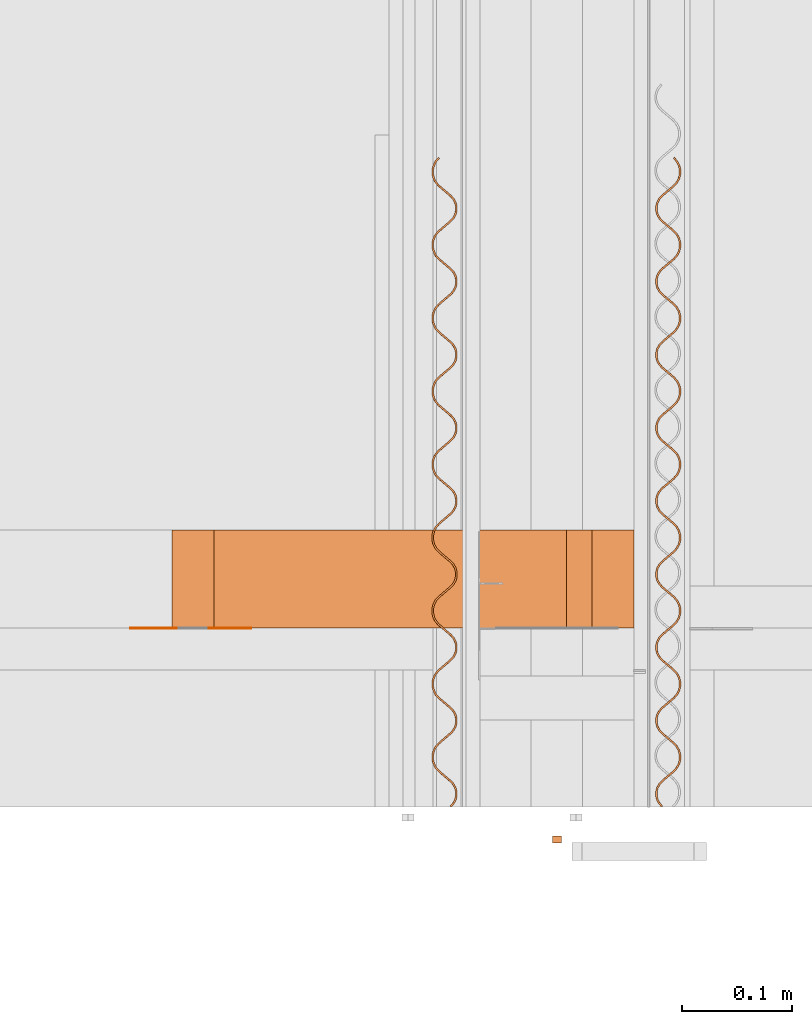
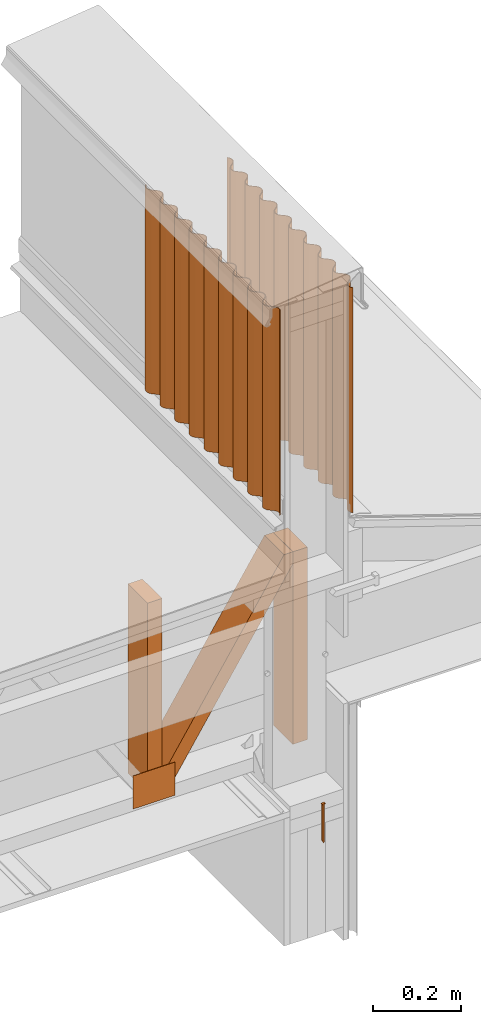
# One storey, part 10 of 22: 7 proxies.
"""IFC2X3 building model written with IfcOpenShell, lengths in feet."""

from ifc_helpers import new_model, entity, si_unit, converted_unit, frame, frame_2d, origin_with_axes, place, context, subcontext, project, spatial, polyline, rectangle, outline, extrude, source, transform, mapped, type_object, type_shapes, element, save


model = new_model("IFC2X3")

# Units and contexts
model_context = context("Model", 3, precision=1e-05)
plan_context = context("Plan", 2, precision=1e-05, world=frame_2d((0.0, 0.0, 0.0), x_axis=(1.0, 0.0, 0.0)))
body_context_1 = subcontext(model_context, "Body", "Model", "MODEL_VIEW")
body_context_2 = subcontext(model_context, "Body", "Model", "MODEL_VIEW")
ifc_project = project(units=[converted_unit("VOLUMEUNIT", "cubic foot", entity("IfcReal", 0.0283168467116885), si_unit("VOLUMEUNIT", "CUBIC_METRE"), dimensions=[3, 0, 0, 0, 0, 0, 0]), converted_unit("AREAUNIT", "square foot", entity("IfcReal", 0.09290304), si_unit("AREAUNIT", "SQUARE_METRE"), dimensions=[2, 0, 0, 0, 0, 0, 0]), converted_unit("LENGTHUNIT", "foot", entity("IfcReal", 0.3048), si_unit("LENGTHUNIT", "METRE"), dimensions=[1, 0, 0, 0, 0, 0, 0])], contexts=[model_context, plan_context])

# Site, building, storey
site_placement = place(None, origin_with_axes())
site = spatial("IfcSite", under=ifc_project, at=site_placement, CompositionType="ELEMENT")
building_placement = place(site_placement, origin_with_axes())
building = spatial("IfcBuilding", under=site, at=building_placement, Name="Building", CompositionType="ELEMENT")
storey_placement = place(building_placement, origin_with_axes())
storey = spatial("IfcBuildingStorey", under=building, at=storey_placement, Name="Storey", CompositionType="ELEMENT")

# Proxies
building_element_proxy_type = type_object("IfcBuildingElementProxyType", PredefinedType="NOTDEFINED")
shared_shape = source(origin_with_axes(), body_context_1, "Body", "SweptSolid", [
    extrude(outline(polyline([(0.111323627313291, -4.3989495809459e-10), (0.11174819796417, -0.00686187809210984), (0.11861007758404, -0.00643729980243003), (0.11691175831428, 0.0210102125660093), (0.110049890916491, 0.0205856327485694), (0.110474473789452, 0.0137237546564596), (-0.222222659531541, -0.00686187580046965), (-0.235521848120402, -0.0145729081802989), (-0.22137349378562, -0.0205856312208093), (0.111323627313291, -4.3989495809459e-10)])), frame((0.111111134212474, 9.54850080601499e-11, -0.0200000086804153), z_axis=(-5.63213937709861e-08, 0.0, -1.0), x_axis=(-0.998091220855713, -0.0617568753659725, 6.86179575382084e-08)), (-2.94874541451051e-10, 4.76513584146687e-09, -0.999999940395355), 0.0199999997321788),
])
type_shapes(building_element_proxy_type, [shared_shape])
proxy_1_placement = place(storey_placement, frame((1615.7385558281, 1.80479852859117, -61.6394691267039), z_axis=(-1.62920684942947e-07, 1.0, -1.23001694617955e-14), x_axis=(7.54979012640433e-08, 0.0, -1.0)))
element("IfcBuildingElementProxy", 1, at=proxy_1_placement, inside=storey, type_object=building_element_proxy_type, context=body_context_1, shape_type="MappedRepresentation", body=[
    mapped(shared_shape, transform((0.0, 0.0, 0.0), x_axis=(1.0, 0.0, 0.0), y_axis=(0.0, 1.0, 0.0), z_axis=(0.0, 0.0, 1.0), scale=1.0)),
])
proxy_2_placement = place(storey_placement, frame((1616.04983912991, 1.89103577237117, -57.2210972703348), z_axis=(-5.64259664770361e-07, -8.02678698619275e-07, 1.0), x_axis=(1.0, 3.25841369885893e-07, 5.64259948987456e-07)))
element("IfcBuildingElementProxy", 2, at=proxy_2_placement, inside=storey, Name="Generic Models 1:Generic Models 1", context=body_context_2, shape_type="SweptSolid", body=[
    extrude(outline(polyline([(-0.165153717685716, 0.164683680893399), (-0.119867326393528, 0.164683680893399), (-0.107156533229695, 0.163006444713419), (-0.0951571629585556, 0.158297594666012), (-0.0846319162137709, 0.150837664177099), (-0.0762915314514962, 0.141000245597575), (-0.0706418561614717, 0.129382020923409), (-0.0679718325613678, 0.116788474182914), (-0.0683844561280384, 0.103960165709961), (-0.0758012976702743, 0.0592933300383917), (-0.0762221772526819, 0.0464747533974607), (-0.0736202917543296, 0.0338066458516312), (-0.0679022644761353, 0.0222627130970163), (-0.0595618491586581, 0.0124253204894152), (-0.0491048902361177, 0.00489097280462035), (-0.0370373879742669, 0.000256724716585833), (-0.0243185419867945, -0.00143010551054911), (0.0209679272211599, -0.00143027385061832), (0.0336706935332751, -0.00309803190224332), (0.0456780601009296, -0.00781619192890608), (0.0561992002264878, -0.0152714321942232), (0.064539639988127, -0.0251088018854224), (0.0701852514362085, -0.0367221866154999), (0.0728635799403735, -0.0493256637968338), (0.072446788644071, -0.0621490009383267), (0.0650217277523414, -0.106806162832759), (0.064601110944676, -0.119625011414993), (0.0672150351928444, -0.132307424906671), (0.0729289069634879, -0.143846377163265), (0.0812652034396575, -0.153678980242862), (0.0917221654177181, -0.161213330983177), (0.103789985453676, -0.165847956332478), (0.116504787460087, -0.167529971346142), (0.161795248705258, -0.167534664625258), (0.174505821871632, -0.169211815250671), (0.186505461028555, -0.173920836407212), (0.197026619487234, -0.181375975840361), (0.205366967583266, -0.191213418864046), (0.211016600096007, -0.202831447984916), (0.213690693649094, -0.215429920224067), (0.213277978416816, -0.228258069809966), (0.205857170809285, -0.272920267201784), (0.205436511224336, -0.285739128006099), (0.208042136679484, -0.298411641612141), (0.213760090625192, -0.309955592699877), (0.222100756495331, -0.319793194610616), (0.232553446856071, -0.32732255874187), (0.24462507407027, -0.331961694039072), (0.257339924965005, -0.33364364794233), (0.302630606207635, -0.333648658995553), (0.3153332594655, -0.335316435284815), (0.327336614135056, -0.34002988083469), (0.337857674817088, -0.347485032489919), (0.346202276197318, -0.35732727879145), (0.351847899867481, -0.368940651299447), (0.354526051151471, -0.381544061259335), (0.354109375964938, -0.394367517566118), (0.346684290629046, -0.439024630572226), (0.346263533267449, -0.451843344711569), (0.348873583115931, -0.464521016035806), (0.354591561505801, -0.476064869346894), (0.362923745251703, -0.485892742481132), (0.373380762229128, -0.493426824335664), (0.385452413887489, -0.498066179630325), (0.398171298068965, -0.499753120142644), (0.443453619408169, -0.499748231310231), (0.456164437016164, -0.501425540822697), (0.468167840574044, -0.506139108593383), (0.478688999032724, -0.513594333581098), (0.48702939601708, -0.523431593273568), (0.492679272971441, -0.535049952390626), (0.495353415412853, -0.547648424629777), (0.494936642449672, -0.560472027601532), (0.487519648131423, -0.60513860049836), (0.487098915213988, -0.617957265749378), (0.489704809554919, -0.630630243794499), (0.49541877910221, -0.642169306049822), (0.503759127198242, -0.652006712407265), (0.514211988668116, -0.659536052094357), (0.526287649169056, -0.664180149556458), (0.539002573396277, -0.665862299013013), (0.58428499251213, -0.665857556845572), (0.596991459059277, -0.667529781972329), (0.608999115901356, -0.672248189687103), (0.619520372136684, -0.679703610228115), (0.627860622456067, -0.689540821032261), (0.633510450522105, -0.70115908237267), (0.636180437455966, -0.713752763556057), (0.63576786888866, -0.726581157583577), (0.640853379029302, -0.727470387311119), (0.641342653377162, -0.713338826115676), (0.638466504380459, -0.699418266927163), (0.632248593988068, -0.686665356472095), (0.623082570985859, -0.675854339139668), (0.611515202390866, -0.6676294163769), (0.598252631156776, -0.66251467101843), (0.584235273086493, -0.660689669878777), (0.539029364197899, -0.660629830570046), (0.52762102932129, -0.659095323852354), (0.516812309740097, -0.654861937201242), (0.507237091464946, -0.648212734013405), (0.499726378229346, -0.639354071904981), (0.494745489102336, -0.628834331207701), (0.492333143636623, -0.617473613558792), (0.492677806321717, -0.605958555470614), (0.50002234814361, -0.561361355105723), (0.500511280273202, -0.547229549468659), (0.497635326829795, -0.533309283610091), (0.491421669721603, -0.52056131087576), (0.482247433480941, -0.509740466990183), (0.470683633733609, -0.501520090841559), (0.45741739587521, -0.496400652203973), (0.443412308774282, -0.494590268673233), (0.398198137758911, -0.494520553923029), (0.386793885057367, -0.492991033814398), (0.375981181077757, -0.488752807219197), (0.366409898312699, -0.482108297310476), (0.358899160632937, -0.473249439648756), (0.353914189330862, -0.462725054560684), (0.351510081547765, -0.451374065688276), (0.351846530994405, -0.439849376600245), (0.359187015085396, -0.395247336291266), (0.359680176055025, -0.3811204928191), (0.356808109233386, -0.367204749130514), (0.350590345505967, -0.354452083117067), (0.341424444724569, -0.343641041340478), (0.329856636134658, -0.335415800803603), (0.31658614499206, -0.330291644442739), (0.302580886781998, -0.328480967582054), (0.257366837987437, -0.328411326164336), (0.245958625331638, -0.32687701499994), (0.235153890148861, -0.322648370516269), (0.22557463858697, -0.315994376272667), (0.218067689752328, -0.307140163001739), (0.213086971734452, -0.296620617857755), (0.210674821822036, -0.285260169094629), (0.211015280111255, -0.273740148841553), (0.218363855219889, -0.229147666199939), (0.218848827395226, -0.215011191727921), (0.215972776175171, -0.201090705871895), (0.209762956800423, -0.188347475305004), (0.200588989445544, -0.177526839194805), (0.189025373029427, -0.169306609711153), (0.175754955219315, -0.164182270019073), (0.161749770341739, -0.162371910932496), (0.116539644835189, -0.162307011682218), (0.105131395513148, -0.160772688295741), (0.0943185693127277, -0.156534388368055), (0.0847433204823748, -0.149885185180217), (0.0772406249319318, -0.141035946296269), (0.0722516447872784, -0.130506635709541), (0.0698476225587483, -0.119155720169619), (0.0701799042757571, -0.107626117805014), (0.0775286138272817, -0.0630338307166976), (0.078017607067279, -0.0489020800789979), (0.0751454852462753, -0.0349863363904121), (0.068927733740938, -0.0222335756558368), (0.059757848561123, -0.0114177703231651), (0.0481901071926584, -0.00319267053119203), (0.0349276337352168, 0.00192212066008145), (0.0209185255696298, 0.00373730460411607), (-0.0242916259088424, 0.00380217864635227), (-0.0357040139330732, 0.00534140499702256), (-0.0465086666168034, 0.00956998646058866), (-0.0560879181786941, 0.0162239325797464), (-0.0635946897931612, 0.0250780816847493), (-0.0685756766968199, 0.0355978926589952), (-0.0709876677221826, 0.0469582467009937), (-0.0706471299894369, 0.058478160010861), (-0.0632986587684924, 0.103070752651203), (-0.0628097205278598, 0.117202448289538), (-0.0656897561463315, 0.131127529648032), (-0.07189946552235, 0.143870784659085), (-0.0810734878765942, 0.154691445213447), (-0.0926371409589537, 0.162911735807504), (-0.10590357437065, 0.168031308887981), (-0.119912816979128, 0.169846569029052), (-0.165126841329527, 0.169916112670122), (-0.176531118475233, 0.171445803887888), (-0.187339911388913, 0.175679153872757), (-0.196919175172885, 0.182333087005953), (-0.204421919611652, 0.191182509221117), (-0.209410863090062, 0.201711709809116), (-0.211818979715738, 0.21306739196064), (-0.211478448094033, 0.224587387769554), (-0.204129848541237, 0.269179821522843), (-0.203636883124905, 0.283306811659981), (-0.206517016520025, 0.297232064127609), (-0.212734706914957, 0.309984705696894), (-0.22190468987142, 0.32080056297341), (-0.233472400684682, 0.329025730177799), (-0.2467348252538, 0.334140451092107), (-0.260740010131375, 0.335950932399494), (-0.305954058925937, 0.336020524928889), (-0.317366524865934, 0.337559822702345), (-0.32816710454116, 0.341783627241928), (-0.337742347260473, 0.348432732653117), (-0.345257216003623, 0.35729647914725), (-0.350238080686472, 0.367816122067882), (-0.352646172867985, 0.37917185310773), (-0.35230564124628, 0.39069180002832), (-0.344961148312711, 0.435289073725698), (-0.344472216183119, 0.44942073269779), (-0.347348242959013, 0.463341242997978), (-0.353562022288015, 0.476089166843985), (-0.362727849736927, 0.486900233064737), (-0.374295633882675, 0.495125400269125), (-0.387566125025274, 0.5002496788508), (-0.401575269857104, 0.502064902325628), (-0.446789416428313, 0.502134568187508), (-0.458189635843117, 0.503659443905347), (-0.46899835542431, 0.507892781668135), (-0.478577631430363, 0.514546727023413), (-0.486088442442611, 0.523405584685133), (-0.491069380457946, 0.533925325382413), (-0.493477374862811, 0.545281007533937), (-0.493136916573592, 0.556801003342851), (-0.485788365909121, 0.601393461540302), (-0.48529933600288, 0.615525169400718), (-0.48817543611126, 0.629445679700906), (-0.494393248727002, 0.642198394602678), (-0.503563231683466, 0.653014300767518), (-0.515126884765825, 0.661234628027818), (-0.528397327020099, 0.666358808832844), (-0.542402560785999, 0.66816938791688), (-0.58761257629382, 0.668234213834672), (-0.599024968901331, 0.66977341383148), (-0.609833688482525, 0.674006800482592), (-0.619404897915097, 0.680651163726341), (-0.626915708927345, 0.689510070276385), (-0.631896549166031, 0.700029762085341), (-0.634304641347545, 0.711385444236865), (-0.633968191900904, 0.72291018221322), (-0.639126398979522, 0.723730137185475), (-0.63955118962786, 0.710916214101896), (-0.636941188667703, 0.698238591665984), (-0.631223308054481, 0.686694738354896), (-0.622882911070125, 0.676857380885778), (-0.612430049600251, 0.669327845645389), (-0.600362357896144, 0.664693379183141), (-0.587643473714668, 0.66300653644747), (-0.542357045756237, 0.663006487559146), (-0.529646325924891, 0.661329275823328), (-0.517646882321265, 0.656620401331759), (-0.507121617243359, 0.649160434176603), (-0.498785375766554, 0.639327916651573), (-0.493139703208067, 0.627714446366928), (-0.490457494193175, 0.615106440904572), (-0.490870160537129, 0.602278144653701), (-0.49829512365221, 0.557620958315106), (-0.498719914300548, 0.544807035231528), (-0.496110011117039, 0.532129461683939), (-0.490396090458071, 0.520590301651967), (-0.48205574236204, 0.510752993071173), (-0.471602783115517, 0.503223457830784), (-0.459527024837929, 0.498579360368684), (-0.446816256118259, 0.496902148632866), (-0.401529828159828, 0.496902050856217), (-0.388819034995995, 0.495224790232075), (-0.376815582549791, 0.49051122246139), (-0.366294448535273, 0.483056095250322), (-0.357954100439242, 0.473218737781204), (-0.352304419038177, 0.461600574217443), (-0.349630252152603, 0.449002004201644), (-0.350042942940719, 0.436173756839096), (-0.357463848324898, 0.391511803888899), (-0.35788465457482, 0.378693089749557), (-0.355278735789727, 0.366020233925246), (-0.349560757399857, 0.354476331725834), (-0.341224418146404, 0.344643716424156), (-0.330771532232367, 0.337114205627929), (-0.318699905018168, 0.332475021442403), (-0.305981020836692, 0.330788227595056), (-0.26069860172084, 0.330792896430011), (-0.247987784112845, 0.329115611361706), (-0.235984331666641, 0.324402043591021), (-0.225459164365383, 0.316942125324189), (-0.21712282511193, 0.307109461134187), (-0.211477152553443, 0.295496039737867), (-0.208798976825291, 0.282892776442951), (-0.20921169205757, 0.270064577968728), (-0.216636557396003, 0.225407318297646), (-0.217057412534248, 0.212588628602466), (-0.214451518193318, 0.19991582166648), (-0.208737646422674, 0.188376771633237), (-0.200393265039902, 0.178534610886273), (-0.189940281349217, 0.171005026757561), (-0.177864510849548, 0.166361002627946), (-0.165153717685716, 0.164683680893399)])), frame((0.0195751630327129, 0.965333790603898, -1.94036096256236), z_axis=(-1.31135011542938e-05, 5.19575087309931e-06, -1.0), x_axis=(0.762758135795593, 0.646683990955353, 4.31814987678081e-06)), (-4.30156906077173e-05, 1.98341331270058e-05, -1.0), 2.04455193995071),
])
proxy_3_placement = place(storey_placement, frame((1615.42366808794, 1.8910676475585, -57.0275777281113), z_axis=(-5.64259664770361e-07, -8.02678698619275e-07, 1.0), x_axis=(1.0, 3.25841369885893e-07, 5.64259948987456e-07)))
element("IfcBuildingElementProxy", 3, at=proxy_3_placement, inside=storey, Name="Generic Models 1:Generic Models 1", context=body_context_2, shape_type="SweptSolid", body=[
    extrude(outline(polyline([(0.229172574801082, 2.45873895754886e-09), (0.240362965528733, -0.00874663527756734), (0.253336411213937, -0.0144376616871224), (0.267314120853354, -0.0168340390039671), (0.281448810901542, -0.015702359854999), (0.294886011229412, -0.0111109693534672), (0.306782544910751, -0.00342872837714831), (0.316438624474007, 0.00698696574430883), (0.342898427696991, 0.0434572346449837), (0.350795994241407, 0.051924136279058), (0.360540855001277, 0.0583292156203682), (0.371524594782844, 0.0621215012560053), (0.383101838819311, 0.0630484483256115), (0.394555395395737, 0.0610526008262565), (0.405182885959392, 0.0562786559752748), (0.414345511223075, 0.0491776421734589), (0.44625237818778, 0.0173805142188166), (0.457442573362135, 0.00863387894124927), (0.470416214600636, 0.00294289588188787), (0.484393924240052, 0.000546475787759512), (0.49852861428824, 0.00167817326984918), (0.511959654687271, 0.00626907431522966), (0.523862152744153, 0.0139517606336262), (0.533512267931866, 0.024367013232406), (0.559978255527852, 0.0608377427527598), (0.567875919848915, 0.0693046749420366), (0.57762249170013, 0.0756094598864007), (0.588598116019892, 0.0795015265915807), (0.600181519985199, 0.0804289625444281), (0.611634978784977, 0.0784331150450732), (0.622262616013604, 0.0736591824161725), (0.631425314609773, 0.0665581777809173), (0.663326021645639, 0.0347605609430338), (0.674522670078778, 0.0260144244791485), (0.687489564728549, 0.0203228839783101), (0.701474020956695, 0.0179270383219902), (0.715608808781531, 0.0190587480261609), (0.729033102591832, 0.0236490866648439), (0.740948018283043, 0.0313327927631265), (0.750591973541916, 0.0417475182846619), (0.777051507879117, 0.0782177558662541), (0.784942816718044, 0.0866841869502086), (0.794702392863476, 0.0929900168825009), (0.80568407933543, 0.0968825908040437), (0.817254967889761, 0.0978089817689629), (0.828716542151343, 0.0957133348669436), (0.839336357248111, 0.0910392321959099), (0.848498811402659, 0.0839382336716952), (0.880405678367364, 0.0521410782173706), (0.89160227791218, 0.0433949600866069), (0.90457567470906, 0.0377039252743712), (0.9185534332368, 0.0353075601796074), (0.932682158909445, 0.0364387748894964), (0.946112954866855, 0.0410296390776637), (0.958027626116445, 0.0487132978153823), (0.967665274781505, 0.0591275191760752), (0.963467821048626, 0.062005684816149), (0.954673300421457, 0.0526633399619362), (0.943851478769397, 0.0456698682511181), (0.931636730986317, 0.0415781660743664), (0.918786532766237, 0.0405492685158343), (0.906076252929808, 0.0426453768014126), (0.89426727823698, 0.0478269494434432), (0.884110924452934, 0.0556519687703745), (0.852182448848965, 0.087648228035746), (0.842005659745434, 0.0955720170550146), (0.830188862920746, 0.100853441043554), (0.817502342809842, 0.102951428474091), (0.804646473544163, 0.101922115364804), (0.792419063685134, 0.0978293682001238), (0.78159919756604, 0.0907355684816368), (0.772825307811652, 0.0812944875458094), (0.746388017661928, 0.044625130875569), (0.737600292511812, 0.035283400180928), (0.726778519748077, 0.0282898887483467), (0.714563234193431, 0.0241980964337473), (0.701707169374456, 0.0231687588802981), (0.689002316142005, 0.0252653163273543), (0.677187425961957, 0.0304464168915051), (0.667031023289588, 0.0382714301073958), (0.635101912137405, 0.0702676649286052), (0.624925611917115, 0.0781914478368334), (0.613115072797915, 0.0834733668196545), (0.600416477270952, 0.085570425372033), (0.587566767934113, 0.0845415889239061), (0.575345420227276, 0.0804493306424674), (0.564519394179342, 0.0733550420407392), (0.555745308871657, 0.0639139488828307), (0.529307920945285, 0.0272445861015498), (0.520520098018521, 0.0179028111018651), (0.50970477851357, 0.0109098107050469), (0.497483137476788, 0.0068175157573651), (0.484620814952325, 0.00578770765379619), (0.471916352826466, 0.0078842956560549), (0.460113586950803, 0.0130663625284873), (0.449951317679538, 0.0208908822778563), (0.418022206527355, 0.052887107932505), (0.407852164012553, 0.0608114469454201), (0.396047809266356, 0.06609382425628), (0.383343347140497, 0.0681904244806197), (0.370487184544874, 0.067161068594049), (0.35826564128474, 0.0630688042015698), (0.347439395239347, 0.05597449726672), (0.338665627705769, 0.0465334163308926), (0.312228142002749, 0.00986406500781263), (0.303440294631823, 0.000522279409292029), (0.29262495068271, -0.00647070962481025), (0.28040321186928, -0.0105630290166541), (0.267547342603601, -0.0115923176817792), (0.254836720548903, -0.00949623078484274), (0.243040041269593, -0.00431366509872824), (0.232871832066946, 0.00351036767709971), (0.200948685290307, 0.0355070703748486), (0.190778630553425, 0.0434314032767232), (0.178967993657576, 0.0487132855933013), (0.166257078272933, 0.0508093663791972), (0.153407368936094, 0.0497805452086716), (0.141185825675961, 0.0456882685941114), (0.130359799628026, 0.0385939830479034), (0.121585922095719, 0.0291528746123937), (0.0951608479159867, -0.00751547755556196), (0.0863604973561651, -0.0168582494187308), (0.075532637996076, -0.0238522314014319), (0.0633172546647821, -0.0279440374658724), (0.0504738030334314, -0.028972360586596), (0.0377568224410764, -0.0268767656284211), (0.0259480219129033, -0.0216951715977486), (0.0157980847213994, -0.0138696817206977), (-0.0161310233752637, 0.0181265378229105), (-0.026301175888794, 0.0260508768358256), (-0.0381120052824183, 0.0313327560968834), (-0.0508164643527563, 0.0334293288215408), (-0.0636786921560921, 0.0323995176624516), (-0.0759003331928741, 0.0283072349368509), (-0.0867076839009921, 0.0212144236791674), (-0.0954876296965312, 0.0117728500406984), (-0.121925023733944, -0.0248964982268613), (-0.130719214364925, -0.0342387758596285), (-0.141540816019526, -0.0412322750701288), (-0.153749892757008, -0.0453235555850849), (-0.166605908687659, -0.0463528809164531), (-0.179322788447846, -0.0442572920693187), (-0.191125529879347, -0.039075209155405), (-0.201281675888015, -0.0312502020505548), (-0.233210677041469, 0.000746020835028653), (-0.243387197259217, 0.00866983706752459), (-0.255197907487551, 0.0139517239673831), (-0.26789620968457, 0.016048776408721), (-0.280758336655737, 0.0150189759439527), (-0.292979928804195, 0.0109266916905918), (-0.303787303956475, 0.00383390067573001), (-0.312567329195541, -0.0056076840389999), (-0.339011023715725, -0.0422775410506825), (-0.347799017751624, -0.0516193175781274), (-0.358620619406225, -0.0586127923444657), (-0.370829598367058, -0.0627040789704623), (-0.383691872003197, -0.0637339054071528), (-0.396390027535243, -0.0616368285216528), (-0.40820538215437, -0.0564557722625457), (-0.418355233791306, -0.0486302396082112), (-0.450290455984005, -0.0166345013090436), (-0.460466951757591, -0.0087106817345724), (-0.472271428724599, -0.00342830862505288), (-0.484982295220918, -0.00133224922779879), (-0.497825746852269, -0.00236056165420145), (-0.510047241224079, -0.00645283406742132), (-0.520867058454849, -0.0135466383691887), (-0.529647059249753, -0.0229882020772168), (-0.556084691617745, -0.0596575786083389), (-0.564872563432834, -0.0689993368026622), (-0.575694189531597, -0.0759928421242031), (-0.587915635015082, -0.0800851248498038), (-0.600771650945733, -0.0811144318480504), (-0.61347621084824, -0.0790178744009943), (-0.625278878947255, -0.0738357914870805), (-0.635447503700657, -0.0660117835373547), (-0.66737021048238, -0.0340150414997824), (-0.677540546327125, -0.0260907299865497), (-0.689357489816786, -0.0208093472475338), (-0.702055792013804, -0.0187122688342736), (-0.714899292533479, -0.0197405934827573), (-0.727127044610777, -0.0238333742581601), (-0.737953119547035, -0.0309276643876485), (-0.746726764859803, -0.0403687361569151), (-0.773158188410631, -0.0770376100549548), (-0.781946158002368, -0.0863793865823996), (-0.792773944029971, -0.0933733746761412), (-0.80499543840178, -0.097465657401742), (-0.817845196626944, -0.0984944755167473), (-0.83055591645829, -0.0963984008418919), (-0.84235863344563, -0.0912163118169377), (-0.852520951605219, -0.0833918027618895), (-0.884456173797918, -0.0513960568239213), (-0.894626509642664, -0.0434717422551683), (-0.906424728904183, -0.0381888760610672), (-0.919129239918366, -0.03609230639193), (-0.931985304737341, -0.0371216225567374), (-0.944206799109151, -0.0412139022268179), (-0.955032825157085, -0.0483081999951069), (-0.963800261652689, -0.0577487523259297), (-0.959580221514064, -0.0608259728887263), (-0.951676446152484, -0.0523585334830866), (-0.941931634280938, -0.0459534877524992), (-0.930941441240586, -0.0421606826784182), (-0.919376712615096, -0.0412347469860175), (-0.907916898333181, -0.043230068935888), (-0.897289749987795, -0.0480040657307141), (-0.888126806950006, -0.0551050489773275), (-0.856220037761949, -0.086902167765409), (-0.845029695922621, -0.0956488145011773), (-0.832056201349093, -0.10133981875821), (-0.818072234004188, -0.103735707191814), (-0.803937397291028, -0.102604003598684), (-0.790512761262458, -0.0980136221827172), (-0.778603858835115, -0.0903304126064765), (-0.768953890312375, -0.0799151829240985), (-0.742494209310201, -0.0434449392314658), (-0.73459669165411, -0.0349780162087497), (-0.724851733117592, -0.02857294297848), (-0.7138679444477, -0.0247806527595625), (-0.70230321582221, -0.0238547170671617), (-0.69083729049978, -0.0258495608281119), (-0.680209799936124, -0.0306235148456544), (-0.671046954674984, -0.0377245072588285), (-0.639140185486926, -0.0695216413245113), (-0.627956150241411, -0.0782687830545614), (-0.614970140256907, -0.0839587789899095), (-0.60099243061749, -0.0863551746398758), (-0.586863949386466, -0.0852239782631084), (-0.573433055652408, -0.08063310185286), (-0.561524153225065, -0.0729498922766194), (-0.551880442407813, -0.0625351636995637), (-0.525414357035179, -0.0260644097350479), (-0.517516888267412, -0.0175974867123318), (-0.507784396253546, -0.0111934004151055), (-0.496794447654814, -0.00740062895174727), (-0.485210897024535, -0.00647318994337962), (-0.47376374481857, -0.00846953014537614), (-0.46313620536659, -0.0132434833990386), (-0.453967249064934, -0.0203439884567315), (-0.42206668869404, -0.0521416098778955), (-0.410876395743037, -0.0608882505026233), (-0.397896692352345, -0.0665787475432937), (-0.383925093753444, -0.0689756320765012), (-0.36978404822312, -0.0678434334890892), (-0.356359509971198, -0.0632530765172847), (-0.344444349838367, -0.0555693658357217), (-0.334800541244467, -0.0451546219810648), (-0.308340835798131, -0.00868437370515167), (-0.300449624735852, -0.00021794474573856), (-0.290698408493845, 0.00618762216589406), (-0.27970841100679, 0.00998040546939324), (-0.268137375787487, 0.0109068453226366), (-0.256683965876034, 0.00891100775372247), (-0.246062830794515, 0.00413653391579611), (-0.236893727827886, -0.00296393600341392), (-0.204993155234911, -0.0347615662091986), (-0.193796543468015, -0.0435077087841244), (-0.18082308556073, -0.0491987130411575), (-0.166845290366746, -0.0515951117466441), (-0.152710649206882, -0.0504634112090342), (-0.139279596585771, -0.0458725286877453), (-0.12736444867502, -0.0381888088396215), (-0.11772715445031, -0.0277745905344489), (-0.0912674245598122, 0.00869566156086451), (-0.0833636064209494, 0.0171630879805431), (-0.0736186601065119, 0.0235681581552925), (-0.0626350242126332, 0.0273604330966088), (-0.0510577771206462, 0.0282873587775731), (-0.039604122767572, 0.026291557111022), (-0.0289705578296438, 0.0215180828101601), (-0.0198139122191064, 0.0144165785973427), (0.012092761483943, -0.0173805508850597), (0.0232832614464436, -0.0261271762321862), (0.0362563267193754, -0.0318182171554625), (0.0502345130199522, -0.0342145761391857), (0.0643690075148435, -0.0330828969902176), (0.0778064156180917, -0.0284915072525658), (0.0897028393007013, -0.0208092723872874), (0.0993525511597398, -0.0103940740239921), (0.125812281050238, 0.0260761795990814), (0.13371609307806, 0.0345435976160793), (0.143461051614579, 0.0409486769573895), (0.154451134656201, 0.0447415064756326), (0.166015863281692, 0.0456674268904321), (0.177475384233661, 0.0436720621632779), (0.188102887019398, 0.0388980867570936), (0.197265793390944, 0.0317971218436018), (0.229172574801082, 2.45873895754886e-09)])), frame((-0.0194552033073868, 0.965128264089269, -1.94056727129018), z_axis=(-0.000112359448394272, 4.8767146836326e-06, -1.0), x_axis=(-0.0798097923398018, 0.996810138225555, 1.10929186121211e-05)), (9.21778264455497e-05, -5.54182479390875e-05, -1.0), 1.85124268253027),
])
proxy_4_placement = place(storey_placement, frame((1610.96127327346, 2.42488121423196, -61.8508731912127), z_axis=(0.0, 0.0, 1.0), x_axis=(1.0, 0.0, 0.0)))
element("IfcBuildingElementProxy", 4, at=proxy_4_placement, inside=storey, Name="Generic Models 855:Generic Models 1", context=body_context_1, shape_type="SweptSolid", body=[
    extrude(rectangle(XDim=0.124999233345449, YDim=0.291669311091376, at=frame_2d((0.0, 0.0, 0.0))), frame((3.69392433191535, 0.145834848636717, 0.333333109307477), z_axis=(-1.56443593368749e-06, 0.0, -1.0), x_axis=(-0.999999940395355, 0.0, 1.56443593368749e-06)), (9.58482360147173e-07, 0.0, -1.0), 1.72116860376226),
])
proxy_5_placement = place(storey_placement, frame((1612.21131252179, 2.42488121423196, -61.8508731912127), z_axis=(0.0, 0.0, 1.0), x_axis=(1.0, 0.0, 0.0)))
element("IfcBuildingElementProxy", 5, at=proxy_5_placement, inside=storey, Name="Generic Models 855:Generic Models 1", context=body_context_1, shape_type="SweptSolid", body=[
    extrude(rectangle(XDim=0.124999233345449, YDim=0.291669311091376, at=frame_2d((0.0, 0.0, 0.0))), frame((3.69392433191535, 0.145834848636717, 0.333333109307477), z_axis=(-1.56443593368749e-06, 0.0, -1.0), x_axis=(0.999999940395355, 0.0, -1.56443593368749e-06)), (-9.68473727880337e-07, 0.0, -1.0), 1.75002364560732),
])
proxy_6_placement = place(storey_placement, frame((1612.25096134376, 2.42211120178693, -61.6217035008228), z_axis=(0.0, 0.0, 1.0), x_axis=(1.0, 0.0, 0.0)))
element("IfcBuildingElementProxy", 6, at=proxy_6_placement, inside=storey, Name="Generic Models 852:Generic Models 1", context=body_context_1, shape_type="SweptSolid", body=[
    extrude(rectangle(XDim=0.360929982303518, YDim=0.00277022707595213, at=frame_2d((0.0, 0.0, 0.0))), frame((2.39778886942726, 0.00138511354766121, 0.0), z_axis=(0.0, 0.0, -1.0), x_axis=(-1.0, 0.0, 0.0)), (0.0, 0.0, -1.0), 0.301264184929359),
])
proxy_7_placement = place(storey_placement, frame((1614.28726877127, 2.42488121423196, -61.9758708583401), z_axis=(0.0, 0.0, 1.0), x_axis=(1.0, 0.0, 0.0)))
element("IfcBuildingElementProxy", 7, at=proxy_7_placement, inside=storey, Name="Generic Models 855:Generic Models 1", context=body_context_1, shape_type="SweptSolid", body=[
    extrude(outline(polyline([(-0.999140457844171, -0.0614845963913625), (0.948410412770869, -0.0614845475030383), (1.04022747653676, -0.00280682535309178), (0.999140751174116, 0.0614844497263901), (-0.948410119440925, 0.0614842052847695), (-1.04022718320681, 0.0028066786881194), (-0.999140457844171, -0.0614845963913625)])), frame((0.992949631583346, 2.20078280475601e-07, 1.33334553930077), z_axis=(3.70477182265461e-09, -1.0, -2.96325826099064e-08), x_axis=(-0.538498818874359, 2.2916697872688e-08, -0.842626333236694)), (2.29167156362564e-08, 3.54313101524895e-07, -1.0), 0.291666664589773),
])

save(model, "model.ifc")
